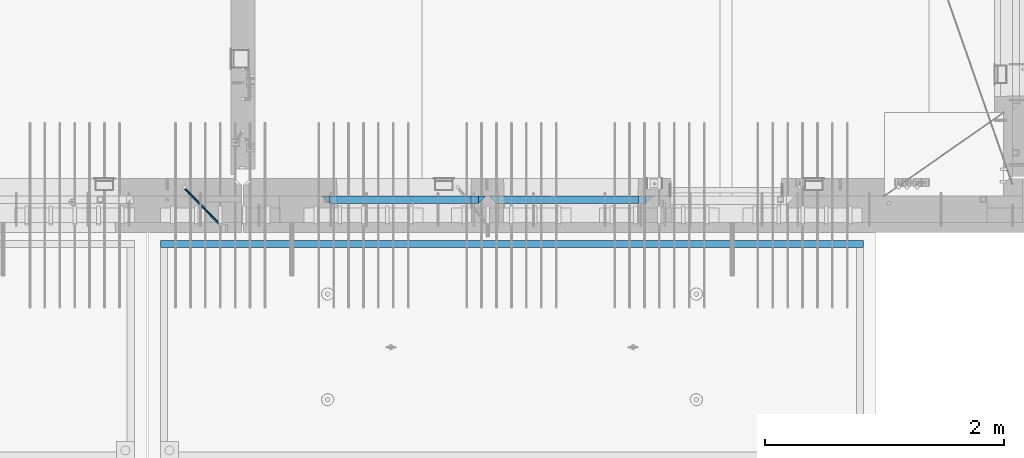
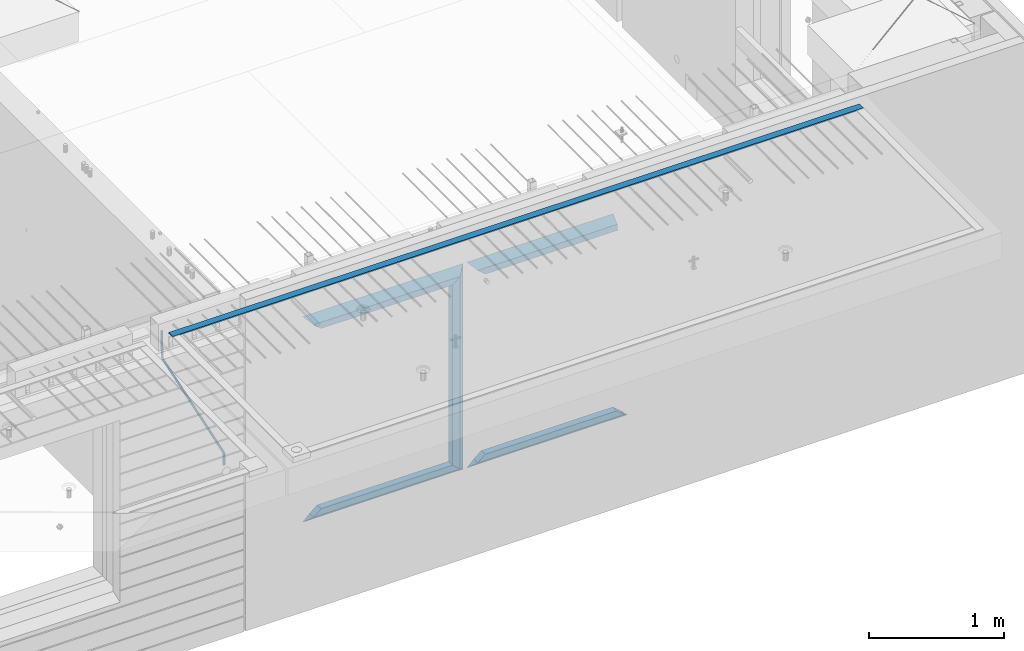
# One storey, part 92 of 334: 12 beams, 3 elements without a shape of their own.
"""IFC2X3 building model written with IfcOpenShell, lengths in millimetres."""

from ifc_helpers import new_model, si_unit, frame, origin_with_axes, place, context, subcontext, project, spatial, faceted_brep, material, type_object, element, aggregate, save


model = new_model("IFC2X3")

# Units and contexts
model_context = context("Model", 3, precision=1e-05, world=origin_with_axes())
body_context = subcontext(model_context, "Body", "Model", "MODEL_VIEW")
ifc_project = project(units=[si_unit("LENGTHUNIT", "METRE", prefix="MILLI"), si_unit("AREAUNIT", "SQUARE_METRE"), si_unit("VOLUMEUNIT", "CUBIC_METRE"), si_unit("MASSUNIT", "GRAM", prefix="KILO"), si_unit("TIMEUNIT", "SECOND"), si_unit("PLANEANGLEUNIT", "RADIAN"), si_unit("SOLIDANGLEUNIT", "STERADIAN"), si_unit("THERMODYNAMICTEMPERATUREUNIT", "DEGREE_CELSIUS"), si_unit("LUMINOUSINTENSITYUNIT", "LUMEN")], contexts=[model_context])

# Site, building, storey
site_placement = place(None, origin_with_axes())
site = spatial("IfcSite", under=ifc_project, at=site_placement, CompositionType="ELEMENT")
building_placement = place(site_placement, origin_with_axes())
building = spatial("IfcBuilding", under=site, at=building_placement, CompositionType="ELEMENT")
storey_placement = place(building_placement, origin_with_axes())
storey = spatial("IfcBuildingStorey", under=building, at=storey_placement, Name="3", CompositionType="ELEMENT", Elevation=0.0)

# Assembly, beam
assembly_1_placement = place(storey_placement, origin_with_axes())
assembly_1 = element("IfcElementAssembly", 1, at=assembly_1_placement, inside=storey, AssemblyPlace="NOTDEFINED", PredefinedType="REINFORCEMENT_UNIT")
ifc_material_1 = material()
beam_type_1 = type_object("IfcBeamType", Name="D20", PredefinedType="NOTDEFINED")
beam_1_placement = place(assembly_1_placement, frame((28120.0219996506, 7924.99999995055, 90407.5), z_axis=(-0.000415599999849952, -0.999999913638316, 0.0), x_axis=(-0.00018169900008877, 0.0, -0.999999983492737)))
beam_1 = element("IfcBeam", 2, at=beam_1_placement, type_object=beam_type_1, material=ifc_material_1, Name="JM20", ObjectType="D20", context=body_context, shape_type="Brep", body=[
    faceted_brep([(-0.00060564729210455, -9.99999998165731, 0.0), (-0.000428079845733009, -7.07106779890455, -7.07106781186667), (119.575515501536, -7.07830994756296, -7.07106481604933), (119.575337932896, -10.0072421307195, -3.43332612828817e-06), (0.0, 0.0, -10.0), (119.575943836026, -0.00724214867295814, -9.99999700418266), (0.00042843479604926, 7.07106779888636, -7.07106781186303), (119.57637202373, 7.06382565022977, -7.07106481604933), (0.00060564729210455, 9.99999998166459, 3.63797880709171e-12), (119.576549238118, 9.99275783300072, 2.99581552098971e-06), (0.000428079845733009, 7.07106779890819, 7.07106781186667), (119.576371669405, 7.06382565024978, 7.07107080768037), (0.0, 0.0, 10.0), (119.57594333493, -0.00724214864203532, 10.0000029958155), (-0.000428434810601175, -7.07106779888272, 7.07106781186667), (119.575515147211, -7.07830994754295, 7.07107080768037), (123.007838984922, -7.07805953274146, -6.96781646693489), (122.583416564885, -10.0070226667376, 0.0904895847234002), (123.182432386879, -0.00697902713727672, -9.89150957511447), (123.004922326727, 7.0640757898218, -6.96792996825661), (122.579291790258, 9.99297690664025, 0.09032907062101), (122.154869373029, 7.06401377197108, 7.14863512328429), (121.980275971029, -0.00706673364766175, 10.0723282314621), (122.157786031181, -7.0781215506031, 7.1487486246051), (232.991069545737, -7.0553235628031, -0.344989315878593), (232.56664713427, -9.98428669916029, 6.71331673826626), (233.165662947809, 0.0157569427356066, -3.26868242414184), (232.988152887861, 7.08681175970924, -0.345102817348561), (232.562522351524, 10.0157128766077, 6.71315622151724), (232.138099934426, 7.08674974201131, 13.7714622742333), (231.963506532353, 0.0156692364653281, 16.6951553824965), (232.141016592301, -7.05538558050466, 13.7715757757042), (248.076986635424, -5.5847993905918, 1.85861828010275), (247.029610002806, -8.57448599522468, 8.8259290931519), (244.875536996158, -5.81406760439131, 15.6317136598209), (242.87659436863, 1.07944012639928, 18.2892356835691), (242.20373560088, 8.06791386077748, 15.2417548051744), (243.251112233527, 11.0576004654249, 8.27444399212709), (245.405185240103, 8.29718207458427, 1.4686594254481), (247.40412786763, 1.40367434377549, -1.1888625983047), (260.566830172145, 5.47100196453175, 3.19131575132906), (262.023113325369, -1.27539050352425, 6.49949830426976), (256.884070167318, 11.8442033958454, 5.28851055269934), (253.132144174728, 14.110878827727, 11.5625744366826), (251.508879555811, 10.9432405336265, 18.3382458712176), (252.965162709021, 4.19684806558143, 21.6464284241465), (256.647922713819, -2.17635336575768, 19.5492336227662), (260.399848700399, -4.44302879667157, 13.2751697364092), (1011.72756124764, 322.959435794994, 337.688425673249), (1010.10429662876, 319.79179750097, 344.464097107826), (1010.27127809466, 329.705828263024, 334.380243120345), (1006.58851809015, 336.079029694381, 336.477437921801), (1002.83659209782, 338.345705126318, 342.751501805859), (1001.21332747894, 335.178066832297, 349.527173240437), (1002.66961063194, 328.431674364263, 352.835355793341), (1006.35237063644, 322.058472932906, 350.738160991886), (1012.15285167976, 323.143366902459, 337.876301685487), (1011.27592458235, 320.298507294498, 344.981674676291), (1011.36533099508, 330.178988123705, 334.863551186057), (1009.37468146477, 337.283999466545, 337.708251560521), (1007.34699858574, 340.296381647149, 344.744015910405), (1006.47007148832, 337.45152203918, 351.849388901209), (1007.25759217299, 330.415900817941, 354.862139400639), (1009.24824170329, 323.310889475106, 352.017439026175), (1012.6528516715, 323.14345775195, 337.876301647731), (1012.65336908352, 320.298757574768, 344.981674572278), (1012.65157305435, 330.179221832586, 334.863551088932), (1012.65028222866, 337.284594639881, 337.708251313175), (1012.64973534261, 340.297345149043, 344.744015509988), (1012.65025275464, 337.452644971851, 351.849388434534), (1012.65153137178, 330.416880891225, 354.862138993334), (1012.65282219746, 323.311508083931, 352.017438769089), (1117.44132683994, 323.162497711652, 337.876293734989), (1117.44184425197, 320.31779753447, 344.981666659536), (1117.44004822278, 330.198261792288, 334.863543176189), (1117.43875739709, 337.303634599582, 337.708243400433), (1117.43821051104, 340.316385108745, 344.744007597245), (1117.43872792307, 337.471684931556, 351.849380521792), (1117.44000654022, 330.435920850927, 354.862131080592), (1117.44129736591, 323.330548043632, 352.017430856347)], [[[0, 1, 2, 3]], [[1, 4, 5, 2]], [[4, 6, 7, 5]], [[6, 8, 9, 7]], [[8, 10, 11, 9]], [[10, 12, 13, 11]], [[12, 14, 15, 13]], [[14, 0, 3, 15]], [[14, 12, 10, 8, 6, 4, 1, 0]], [[3, 2, 16, 17]], [[2, 5, 18, 16]], [[5, 7, 19, 18]], [[7, 9, 20, 19]], [[9, 11, 21, 20]], [[11, 13, 22, 21]], [[13, 15, 23, 22]], [[15, 3, 17, 23]], [[17, 16, 24, 25]], [[16, 18, 26, 24]], [[18, 19, 27, 26]], [[19, 20, 28, 27]], [[20, 21, 29, 28]], [[21, 22, 30, 29]], [[22, 23, 31, 30]], [[23, 17, 25, 31]], [[25, 24, 32, 33]], [[31, 25, 33, 34]], [[30, 31, 34, 35]], [[29, 30, 35, 36]], [[28, 29, 36, 37]], [[27, 28, 37, 38]], [[26, 27, 38, 39]], [[24, 26, 39, 32]], [[39, 40, 41, 32]], [[38, 42, 40, 39]], [[37, 43, 42, 38]], [[36, 44, 43, 37]], [[35, 45, 44, 36]], [[34, 46, 45, 35]], [[33, 47, 46, 34]], [[32, 41, 47, 33]], [[47, 41, 48, 49]], [[41, 40, 50, 48]], [[40, 42, 51, 50]], [[42, 43, 52, 51]], [[43, 44, 53, 52]], [[44, 45, 54, 53]], [[45, 46, 55, 54]], [[46, 47, 49, 55]], [[49, 48, 56, 57]], [[48, 50, 58, 56]], [[50, 51, 59, 58]], [[51, 52, 60, 59]], [[52, 53, 61, 60]], [[53, 54, 62, 61]], [[54, 55, 63, 62]], [[55, 49, 57, 63]], [[57, 56, 64, 65]], [[56, 58, 66, 64]], [[58, 59, 67, 66]], [[59, 60, 68, 67]], [[60, 61, 69, 68]], [[61, 62, 70, 69]], [[62, 63, 71, 70]], [[63, 57, 65, 71]], [[65, 64, 72, 73]], [[64, 66, 74, 72]], [[66, 67, 75, 74]], [[67, 68, 76, 75]], [[68, 69, 77, 76]], [[69, 70, 78, 77]], [[70, 71, 79, 78]], [[71, 65, 73, 79]], [[74, 75, 76, 77, 78, 79, 73, 72]]]),
])
aggregate(assembly_1, [beam_1])

assembly_2_placement = place(storey_placement, origin_with_axes())
assembly_2 = element("IfcElementAssembly", 3, at=assembly_2_placement, inside=storey, AssemblyPlace="NOTDEFINED", PredefinedType="REINFORCEMENT_UNIT")
ifc_material_2 = material(Name="CONCRETE/Concrete_Undefined")
beam_type_2 = type_object("IfcBeamType", PredefinedType="NOTDEFINED")
beam_2_placement = place(assembly_2_placement, frame((33810.0034098489, 7449.93184428067, 90725.278844281), z_axis=(6.5298999993069e-05, -1.00000033840378e-09, 0.99999999786802), x_axis=(-0.999999997792817, 1.22639999974798e-05, 6.52989999859729e-05)))
beam_2 = element("IfcBeam", 4, at=beam_2_placement, type_object=beam_type_2, material=ifc_material_2, context=body_context, shape_type="Brep", body=[
    faceted_brep([(2.5465851649642e-11, 29.9999999999982, -4.99999999998545), (-2.91038304567337e-11, 29.9999999999982, 5.0), (5890.06001043805, 29.9999999999991, 5.00000000001455), (5890.06001043806, 30.0, -4.99999999998545), (-2.5465851649642e-11, -30.0000000000018, 5.0), (5890.06001043806, -30.0, 5.00000000001455), (2.72848410531878e-11, -30.0000000000018, -4.99999999998545), (5890.06001043806, -30.0, -5.0)], [[[0, 1, 2, 3]], [[1, 4, 5, 2]], [[4, 6, 7, 5]], [[6, 0, 3, 7]], [[5, 7, 3, 2]], [[6, 4, 1, 0]]]),
])
aggregate(assembly_2, [beam_2])

# Assembly, beams
assembly_3_placement = place(storey_placement, origin_with_axes())
assembly_3 = element("IfcElementAssembly", 5, at=assembly_3_placement, inside=storey, AssemblyPlace="NOTDEFINED", PredefinedType="REINFORCEMENT_UNIT")
ifc_material_3 = material(Name="CONCRETE/C35/45")
beam_type_3 = type_object("IfcBeamType", PredefinedType="NOTDEFINED")
beam_3_placement = place(assembly_3_placement, frame((30674.9996552717, 7820.0, 90145.0), z_axis=(0.0, 0.0, -1.0), x_axis=(1.0, 0.0, 0.0)))
beam_3 = element("IfcBeam", 6, at=beam_3_placement, type_object=beam_type_3, material=ifc_material_3, Name="SK", context=body_context, shape_type="Brep", body=[
    faceted_brep([(1249.99847412109, -30.0, 30.0), (1249.99847412109, -29.999999998452, -30.0), (1249.99847412109, 30.0, 30.0), (60.0000000000073, -30.0, 30.0), (0.0, -30.0, -30.0), (60.0000000000073, 30.0, 30.0)], [[[0, 1, 2]], [[1, 0, 3, 4]], [[2, 1, 4, 5]], [[0, 2, 5, 3]], [[5, 4, 3]]]),
])
beam_4_placement = place(assembly_3_placement, frame((30734.9996552717, 7820.0, 90085.0), z_axis=(0.0, 0.0, -1.0), x_axis=(1.0, 0.0, 0.0)))
beam_4 = element("IfcBeam", 7, at=beam_4_placement, type_object=beam_type_3, material=ifc_material_3, Name="SK", context=body_context, shape_type="Brep", body=[
    faceted_brep([(1189.99847412109, -30.0, 30.0), (1189.99847412109, -30.0, -30.0), (1189.99847412109, 30.0, -30.0), (1189.99847412109, 30.0, 30.0), (1184.32279844542, 30.0, 30.0), (1185.94442006704, -30.0, 30.0), (1184.32279844542, 29.999999998452, 25.6756756756804), (1185.94442006696, -29.999999998452, 24.0540540541406), (65.6741497967687, 29.999999998452, 25.6756756756804), (64.0525281752307, -29.999999998452, 24.0540540541406), (65.6741497967687, 29.999999998452, 26.2921283848846), (64.0525281752307, -29.999999998452, 24.9021669953072), (0.0, -30.0, -30.0), (0.0, 30.0, -30.0)], [[[0, 1, 2, 3]], [[0, 3, 4, 5]], [[5, 4, 6, 7]], [[7, 6, 8, 9]], [[9, 8, 10, 11]], [[1, 0, 5, 7, 9, 11, 12]], [[2, 1, 12, 13]], [[8, 6, 4, 3, 2, 13, 10]], [[10, 13, 12, 11]]]),
])
ifc_material_4 = material(Name="CONCRETE/C30/37")
beam_5_placement = place(assembly_3_placement, frame((32044.9981293928, 7820.0, 88350.0), z_axis=(0.0, 0.0, 1.0), x_axis=(-1.0, 3.00000001838171e-08, 0.0)))
beam_5 = element("IfcBeam", 8, at=beam_5_placement, type_object=beam_type_3, material=ifc_material_4, Name="SK", context=body_context, shape_type="Brep", body=[
    faceted_brep([(1309.99847412109, 30.0, 30.0), (1309.99847412109, -30.0, 30.0), (1369.99847412109, -30.0, -30.0), (0.0, -30.0, -30.0), (60.0000000000073, 30.0, 30.0), (60.0000000000073, -30.0, 30.0)], [[[0, 1, 2]], [[3, 4, 0, 2]], [[4, 5, 1, 0]], [[5, 3, 2, 1]], [[4, 3, 5]]]),
])
beam_6_placement = place(assembly_3_placement, frame((31984.9981293928, 7820.0, 88410.0), z_axis=(0.0, 0.0, 1.0), x_axis=(-1.0, 3.00000001838171e-08, 0.0)))
beam_6 = element("IfcBeam", 9, at=beam_6_placement, type_object=beam_type_3, material=ifc_material_4, Name="SK", context=body_context, shape_type="Brep", body=[
    faceted_brep([(1185.94594588314, -29.9999988381387, 24.0540541168593), (1184.32432432432, 29.9999988381387, 25.6756756756804), (65.6756756756768, 30.0, 25.6756756756804), (64.0540540540533, -30.0, 24.0540540540533), (1185.94594594586, -29.999999998452, 24.9021669952926), (1184.32432432433, 29.999999998452, 26.2921283848846), (1249.99847412109, -29.999999998452, -30.0), (1249.99847412109, 29.999999998452, -30.0), (0.0, -30.0, -30.0), (0.0, 30.0, -30.0), (65.6756756756768, 30.0, 26.293436281092), (64.0540540540533, -30.0, 24.9034748914419)], [[[0, 1, 2, 3]], [[1, 0, 4, 5]], [[5, 4, 6, 7]], [[8, 9, 7, 6]], [[2, 1, 5, 7, 9, 10]], [[3, 2, 10, 11]], [[6, 4, 0, 3, 11, 8]], [[8, 11, 10, 9]]]),
])
beam_7_placement = place(assembly_3_placement, frame((29275.0000367414, 7820.0, 90145.0), z_axis=(0.0, 0.0, -1.0), x_axis=(1.0, 0.0, 0.0)))
beam_7 = element("IfcBeam", 10, at=beam_7_placement, type_object=beam_type_3, material=ifc_material_3, Name="SK", context=body_context, shape_type="Brep", body=[
    faceted_brep([(60.0000000000073, 30.0, 30.0), (0.0, -30.0, -30.0), (60.0000000000073, -30.0, 30.0), (1370.00038146973, -30.0, -30.0), (1310.0003814697, -30.0, 30.0), (1310.0003814697, 30.0, 30.0)], [[[0, 1, 2]], [[2, 1, 3, 4]], [[0, 2, 4, 5]], [[1, 0, 5, 3]], [[3, 5, 4]]]),
])
beam_8_placement = place(assembly_3_placement, frame((29335.0000367414, 7820.0, 90085.0), z_axis=(0.0, 0.0, -1.0), x_axis=(1.0, 0.0, 0.0)))
beam_8 = element("IfcBeam", 11, at=beam_8_placement, type_object=beam_type_3, material=ifc_material_3, Name="SK", context=body_context, shape_type="Brep", body=[
    faceted_brep([(1185.94632735287, -29.9999988381387, 24.0540541168593), (1184.32470579405, 29.9999988381387, 25.6756756756804), (65.6760571454033, 29.9999988381387, 25.6756756756804), (64.0544355865859, -29.9999988381387, 24.0540541168593), (65.6760571454033, 29.9999988381387, 26.2937632551475), (64.0544355865859, -29.9999988381387, 24.9038019193104), (0.0, 30.0, -30.0), (0.0, -30.0, -30.0), (1250.00038146973, -29.9999988381387, -30.0), (1185.94632735287, -29.9999988381387, 24.9034749452549), (1184.32470579405, 29.9999988381387, 26.2934362810629), (1250.00038146973, 29.9999988381387, -30.0)], [[[0, 1, 2, 3]], [[3, 2, 4, 5]], [[5, 4, 6, 7]], [[0, 3, 5, 7, 8, 9]], [[1, 0, 9, 10]], [[6, 4, 2, 1, 10, 11]], [[7, 6, 11, 8]], [[8, 11, 10, 9]]]),
])
beam_9_placement = place(assembly_3_placement, frame((30615.0004182112, 7820.0, 90175.0), z_axis=(-1.0, 3.00000001838171e-08, 0.0), x_axis=(0.0, 0.0, -1.0)))
beam_9 = element("IfcBeam", 12, at=beam_9_placement, type_object=beam_type_3, material=ifc_material_3, Name="SK", context=body_context, shape_type="Brep", body=[
    faceted_brep([(60.0000000000073, 30.0, 30.0), (0.0, -30.0, -30.0), (60.0000000000073, -30.0, 30.0), (1855.0, -30.0, -30.0), (1795.00000000001, -30.0, 30.0), (1795.00000000001, 30.0, 30.0)], [[[0, 1, 2]], [[3, 4, 2, 1]], [[4, 5, 0, 2]], [[5, 3, 1, 0]], [[4, 3, 5]]]),
])
beam_10_placement = place(assembly_3_placement, frame((30645.0004182112, 7820.0, 88350.0), z_axis=(0.0, 0.0, 1.0), x_axis=(-1.0, 3.00000001838171e-08, 0.0)))
beam_10 = element("IfcBeam", 13, at=beam_10_placement, type_object=beam_type_3, material=ifc_material_4, Name="SK", context=body_context, shape_type="Brep", body=[
    faceted_brep([(1370.00038146973, -30.0, -30.0), (1310.0003814697, 30.0, 30.0), (1310.0003814697, -30.0, 30.0), (0.0, -30.0, -30.0), (60.0000000000073, 30.0, 30.0), (60.0000000000073, -30.0, 30.0)], [[[0, 1, 2]], [[3, 4, 1, 0]], [[4, 5, 2, 1]], [[5, 3, 0, 2]], [[4, 3, 5]]]),
])
beam_11_placement = place(assembly_3_placement, frame((30585.0004182112, 7820.0, 88410.0), z_axis=(0.0, 0.0, 1.0), x_axis=(-1.0, 3.00000001838171e-08, 0.0)))
beam_11 = element("IfcBeam", 14, at=beam_11_placement, type_object=beam_type_3, material=ifc_material_4, Name="SK", context=body_context, shape_type="Brep", body=[
    faceted_brep([(1185.94594588314, -29.9999988381387, 24.0540541168593), (1184.32432432432, 29.9999988381387, 25.6756756756804), (65.6756756756768, 30.0, 25.6756756756804), (64.0540540540533, -30.0, 24.0540540540533), (1185.94594588314, -29.9999988381387, 24.9038019193104), (1184.32432432432, 29.9999988381387, 26.2937632551329), (1250.00038146973, -29.9999988381387, -30.0), (1250.00038146973, 29.9999988381387, -30.0), (0.0, -30.0, -30.0), (0.0, 30.0, -30.0), (65.6756756756768, 30.0, 26.293436281092), (64.0540540540533, -30.0, 24.9034748914419)], [[[0, 1, 2, 3]], [[1, 0, 4, 5]], [[4, 6, 7, 5]], [[8, 9, 7, 6]], [[2, 1, 5, 7, 9, 10]], [[3, 2, 10, 11]], [[6, 4, 0, 3, 11, 8]], [[8, 11, 10, 9]]]),
])
beam_type_4 = type_object("IfcBeamType", PredefinedType="NOTDEFINED")
beam_12_placement = place(assembly_3_placement, frame((30550.0004182112, 7820.0, 90115.0), z_axis=(-1.0, 3.00000001838171e-08, 0.0), x_axis=(0.0, 0.0, -1.0)))
beam_12 = element("IfcBeam", 15, at=beam_12_placement, type_object=beam_type_4, material=ifc_material_3, Name="SK", context=body_context, shape_type="Brep", body=[
    faceted_brep([(0.0, -30.0, -35.0), (54.9034748914273, -30.0, 29.0540540540533), (56.2934362811066, 30.0, 30.6756756756768), (0.0, 30.0, -35.0), (1735.0, -30.0, -35.0), (1680.09652510857, -30.0, 29.0540540540533), (1678.70656371891, 30.0, 30.6756756756768), (1735.0, 30.0, -35.0)], [[[0, 1, 2, 3]], [[1, 0, 4, 5]], [[2, 1, 5, 6]], [[3, 2, 6, 7]], [[7, 4, 0, 3]], [[4, 7, 6, 5]]]),
])
aggregate(assembly_3, [beam_3, beam_4, beam_5, beam_6, beam_7, beam_8, beam_9, beam_12, beam_10, beam_11])

save(model, "model.ifc")
